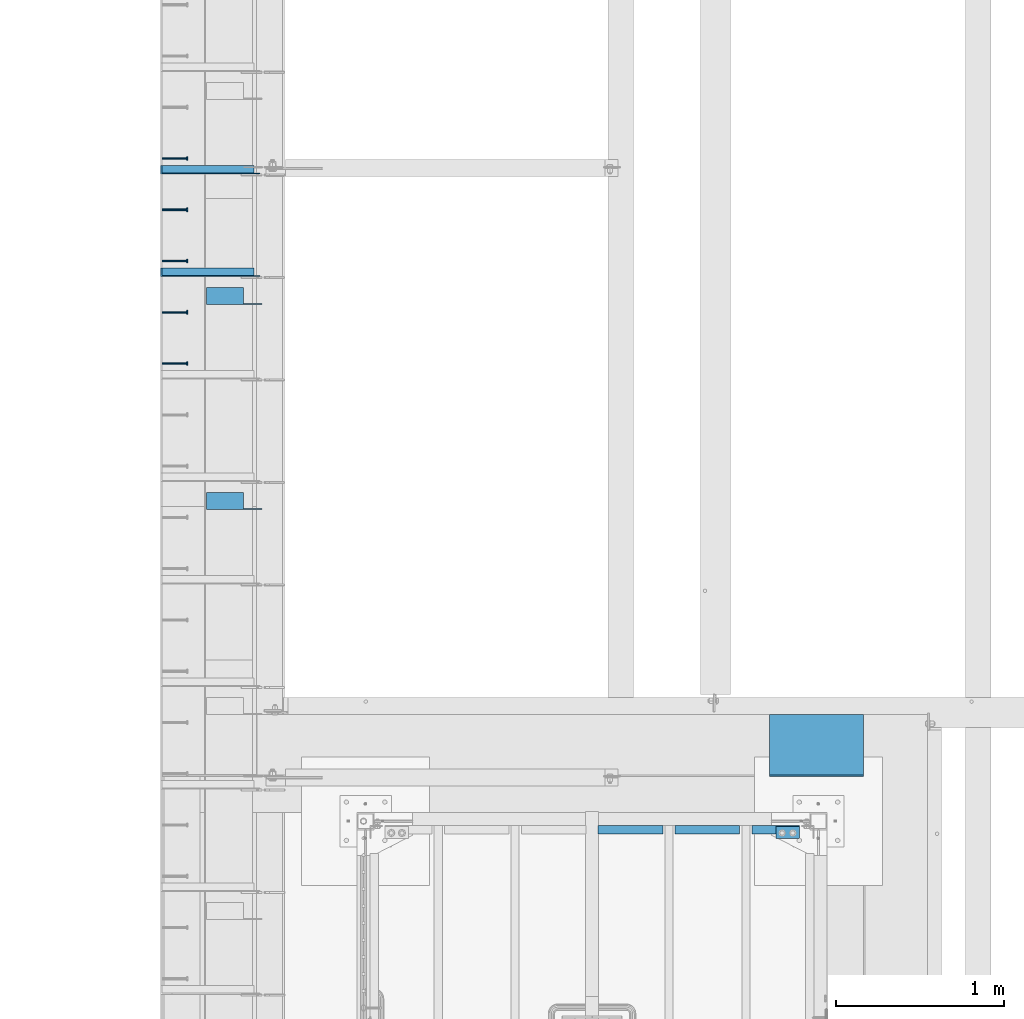
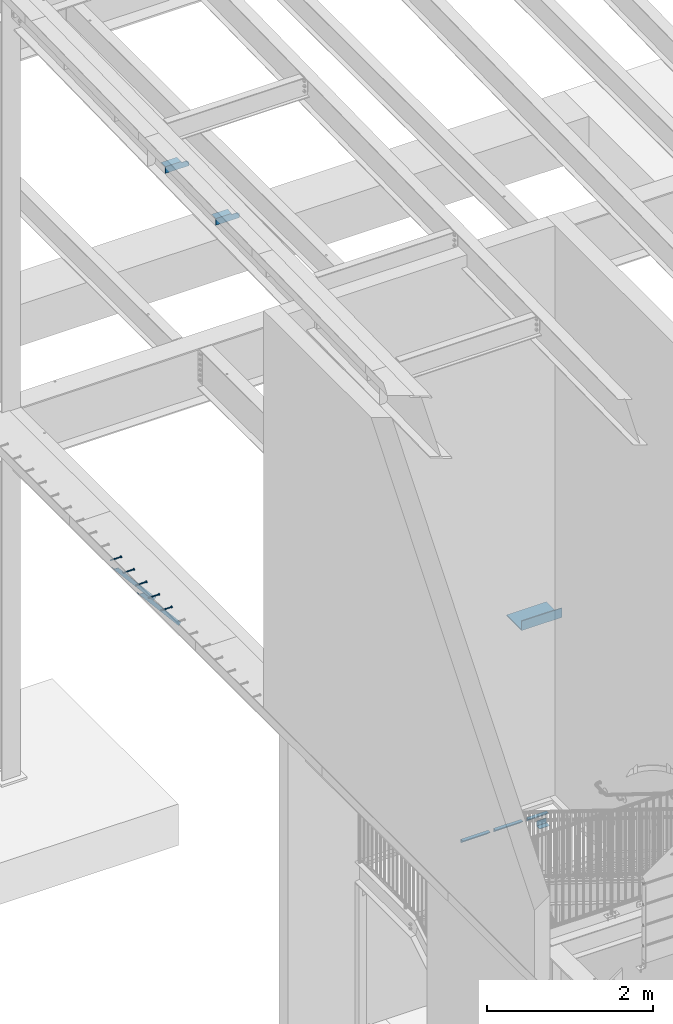
# One storey, part 1278 of 1763: 12 beams, 2 members, 9 elements without a shape of their own.
"""IFC2X3 building model written with IfcOpenShell, lengths in millimetres."""

from ifc_helpers import new_model, si_unit, frame, origin_with_axes, place, context, subcontext, project, spatial, faceted_brep, material, type_object, element, aggregate, save


model = new_model("IFC2X3")

# Units and contexts
model_context = context("Model", 3, precision=1e-05, world=origin_with_axes())
body_context = subcontext(model_context, "Body", "Model", "MODEL_VIEW")
ifc_project = project(units=[si_unit("LENGTHUNIT", "METRE", prefix="MILLI"), si_unit("AREAUNIT", "SQUARE_METRE"), si_unit("VOLUMEUNIT", "CUBIC_METRE"), si_unit("MASSUNIT", "GRAM", prefix="KILO"), si_unit("TIMEUNIT", "SECOND"), si_unit("PLANEANGLEUNIT", "RADIAN"), si_unit("SOLIDANGLEUNIT", "STERADIAN"), si_unit("THERMODYNAMICTEMPERATUREUNIT", "DEGREE_CELSIUS"), si_unit("LUMINOUSINTENSITYUNIT", "LUMEN")], contexts=[model_context])

# Site, building, storey
site_placement = place(None, origin_with_axes())
site = spatial("IfcSite", under=ifc_project, at=site_placement, CompositionType="ELEMENT")
building_placement = place(site_placement, origin_with_axes())
building = spatial("IfcBuilding", under=site, at=building_placement, Name="Undefined", CompositionType="ELEMENT")
storey_placement = place(building_placement, origin_with_axes())
storey = spatial("IfcBuildingStorey", under=building, at=storey_placement, Name="Undefined", CompositionType="ELEMENT", Elevation=0.0)

# Assembly, beam
assembly_1_placement = place(storey_placement, origin_with_axes())
assembly_1 = element("IfcElementAssembly", 1, at=assembly_1_placement, inside=storey, Name="HEADED STUD ANCHOR", AssemblyPlace="NOTDEFINED", PredefinedType="RIGID_FRAME")
ifc_material_1 = material(Name="STEEL/A108")
beam_type_1 = type_object("IfcBeamType", PredefinedType="NOTDEFINED")
beam_1_placement = place(assembly_1_placement, frame((-87975.5122736983, 40020.8750061035, 5268.91250001202), z_axis=(0.0, 0.0, -1.0), x_axis=(1.0, 0.0, 0.0)))
beam_1 = element("IfcBeam", 2, at=beam_1_placement, type_object=beam_type_1, material=ifc_material_1, Name="HEADED STUD ANCHOR", context=body_context, shape_type="Brep", body=[
    faceted_brep([(0.0, -3.1800000667572, 5.5), (0.0, -5.5, 3.1800000667572), (141.732000000002, -5.5, 3.1800000667572), (141.732000000002, -3.1800000667572, 5.5), (0.0, -6.34999999999491, 1.45519152283669e-11), (141.732000000002, -6.34999990463257, 0.0), (0.0, -5.5, -3.1800000667572), (141.732000000002, -5.5, -3.1800000667572), (0.0, -3.1800000667572, -5.5), (141.732000000002, -3.1800000667572, -5.5), (0.0, 0.0, -6.34999990463257), (141.732000000002, 0.0, -6.34999990463257), (0.0, 3.1800000667572, -5.5), (141.732000000002, 3.1800000667572, -5.5), (0.0, 5.5, -3.1800000667572), (141.732000000002, 5.5, -3.1800000667572), (0.0, 6.34999999999491, -2.91038304567337e-11), (141.732000000002, 6.34999990463257, 0.0), (0.0, 5.5, 3.1800000667572), (141.732000000002, 5.5, 3.1800000667572), (0.0, 3.1800000667572, 5.5), (141.732000000002, 3.1800000667572, 5.5), (0.0, 0.0, 6.34999990463257), (141.732000000002, 0.0, 6.34999990463257), (144.780000000001, -10.9899997711182, 6.34999990463257), (144.780000000001, -6.34000015258789, 10.9899997711182), (144.780000000001, -12.6999998092651, 0.0), (144.780000000001, -10.9899997711182, -6.34999990463257), (144.780000000001, -6.34000015258789, -10.9899997711182), (144.780000000001, 0.0, -12.6899995803833), (144.780000000001, 6.34000015258789, -10.9899997711182), (144.780000000001, 10.9899997711182, -6.34999990463257), (144.780000000001, 12.6999998092651, 0.0), (144.780000000001, 10.9899997711182, 6.34999990463257), (144.780000000001, 6.34000015258789, 10.9899997711182), (144.780000000001, 0.0, 12.6899995803833), (152.400000000001, -10.9899997711182, 6.34999990463257), (152.400000000001, -6.34000015258789, 10.9899997711182), (152.400000000001, -12.6999998092651, 0.0), (152.400000000001, -10.9899997711182, -6.34999990463257), (152.400000000001, -6.34000015258789, -10.9899997711182), (152.400000000001, 0.0, -12.6899995803833), (152.400000000001, 6.34000015258789, -10.9899997711182), (152.400000000001, 10.9899997711182, -6.34999990463257), (152.400000000001, 12.6999998092651, 0.0), (152.400000000001, 10.9899997711182, 6.34999990463257), (152.400000000001, 6.34000015258789, 10.9899997711182), (152.400000000001, 0.0, 12.6899995803833)], [[[0, 1, 2, 3]], [[1, 4, 5, 2]], [[4, 6, 7, 5]], [[6, 8, 9, 7]], [[8, 10, 11, 9]], [[10, 12, 13, 11]], [[12, 14, 15, 13]], [[14, 16, 17, 15]], [[16, 18, 19, 17]], [[18, 20, 21, 19]], [[20, 22, 23, 21]], [[22, 0, 3, 23]], [[22, 20, 18, 16, 14, 12, 10, 8, 6, 4, 1, 0]], [[3, 2, 24, 25]], [[2, 5, 26, 24]], [[5, 7, 27, 26]], [[7, 9, 28, 27]], [[9, 11, 29, 28]], [[11, 13, 30, 29]], [[13, 15, 31, 30]], [[15, 17, 32, 31]], [[17, 19, 33, 32]], [[19, 21, 34, 33]], [[21, 23, 35, 34]], [[23, 3, 25, 35]], [[25, 24, 36, 37]], [[24, 26, 38, 36]], [[26, 27, 39, 38]], [[27, 28, 40, 39]], [[28, 29, 41, 40]], [[29, 30, 42, 41]], [[30, 31, 43, 42]], [[31, 32, 44, 43]], [[32, 33, 45, 44]], [[33, 34, 46, 45]], [[34, 35, 47, 46]], [[35, 25, 37, 47]], [[38, 39, 40, 41, 42, 43, 44, 45, 46, 47, 37, 36]]]),
])
aggregate(assembly_1, [beam_1])

assembly_2_placement = place(storey_placement, origin_with_axes())
assembly_2 = element("IfcElementAssembly", 3, at=assembly_2_placement, inside=storey, Name="HEADED STUD ANCHOR", AssemblyPlace="NOTDEFINED", PredefinedType="RIGID_FRAME")
beam_2_placement = place(assembly_2_placement, frame((-87975.5122736983, 40325.6750061035, 5268.91250001202), z_axis=(0.0, 0.0, -1.0), x_axis=(1.0, 0.0, 0.0)))
beam_2 = element("IfcBeam", 4, at=beam_2_placement, type_object=beam_type_1, material=ifc_material_1, Name="HEADED STUD ANCHOR", context=body_context, shape_type="Brep", body=[
    faceted_brep([(0.0, -3.1800000667572, 5.5), (0.0, -5.5, 3.1800000667572), (141.732000000002, -5.5, 3.1800000667572), (141.732000000002, -3.1800000667572, 5.5), (0.0, -6.34999999999491, 1.45519152283669e-11), (141.732000000002, -6.34999990463257, 0.0), (0.0, -5.5, -3.1800000667572), (141.732000000002, -5.5, -3.1800000667572), (0.0, -3.1800000667572, -5.5), (141.732000000002, -3.1800000667572, -5.5), (0.0, 0.0, -6.34999990463257), (141.732000000002, 0.0, -6.34999990463257), (0.0, 3.1800000667572, -5.5), (141.732000000002, 3.1800000667572, -5.5), (0.0, 5.5, -3.1800000667572), (141.732000000002, 5.5, -3.1800000667572), (0.0, 6.34999999999491, -2.91038304567337e-11), (141.732000000002, 6.34999990463257, 0.0), (0.0, 5.5, 3.1800000667572), (141.732000000002, 5.5, 3.1800000667572), (0.0, 3.1800000667572, 5.5), (141.732000000002, 3.1800000667572, 5.5), (0.0, 0.0, 6.34999990463257), (141.732000000002, 0.0, 6.34999990463257), (144.780000000001, -10.9899997711182, 6.34999990463257), (144.780000000001, -6.34000015258789, 10.9899997711182), (144.780000000001, -12.6999998092651, 0.0), (144.780000000001, -10.9899997711182, -6.34999990463257), (144.780000000001, -6.34000015258789, -10.9899997711182), (144.780000000001, 0.0, -12.6899995803833), (144.780000000001, 6.34000015258789, -10.9899997711182), (144.780000000001, 10.9899997711182, -6.34999990463257), (144.780000000001, 12.6999998092651, 0.0), (144.780000000001, 10.9899997711182, 6.34999990463257), (144.780000000001, 6.34000015258789, 10.9899997711182), (144.780000000001, 0.0, 12.6899995803833), (152.400000000001, -10.9899997711182, 6.34999990463257), (152.400000000001, -6.34000015258789, 10.9899997711182), (152.400000000001, -12.6999998092651, 0.0), (152.400000000001, -10.9899997711182, -6.34999990463257), (152.400000000001, -6.34000015258789, -10.9899997711182), (152.400000000001, 0.0, -12.6899995803833), (152.400000000001, 6.34000015258789, -10.9899997711182), (152.400000000001, 10.9899997711182, -6.34999990463257), (152.400000000001, 12.6999998092651, 0.0), (152.400000000001, 10.9899997711182, 6.34999990463257), (152.400000000001, 6.34000015258789, 10.9899997711182), (152.400000000001, 0.0, 12.6899995803833)], [[[0, 1, 2, 3]], [[1, 4, 5, 2]], [[4, 6, 7, 5]], [[6, 8, 9, 7]], [[8, 10, 11, 9]], [[10, 12, 13, 11]], [[12, 14, 15, 13]], [[14, 16, 17, 15]], [[16, 18, 19, 17]], [[18, 20, 21, 19]], [[20, 22, 23, 21]], [[22, 0, 3, 23]], [[22, 20, 18, 16, 14, 12, 10, 8, 6, 4, 1, 0]], [[3, 2, 24, 25]], [[2, 5, 26, 24]], [[5, 7, 27, 26]], [[7, 9, 28, 27]], [[9, 11, 29, 28]], [[11, 13, 30, 29]], [[13, 15, 31, 30]], [[15, 17, 32, 31]], [[17, 19, 33, 32]], [[19, 21, 34, 33]], [[21, 23, 35, 34]], [[23, 3, 25, 35]], [[25, 24, 36, 37]], [[24, 26, 38, 36]], [[26, 27, 39, 38]], [[27, 28, 40, 39]], [[28, 29, 41, 40]], [[29, 30, 42, 41]], [[30, 31, 43, 42]], [[31, 32, 44, 43]], [[32, 33, 45, 44]], [[33, 34, 46, 45]], [[34, 35, 47, 46]], [[35, 25, 37, 47]], [[38, 39, 40, 41, 42, 43, 44, 45, 46, 47, 37, 36]]]),
])
aggregate(assembly_2, [beam_2])

assembly_3_placement = place(storey_placement, origin_with_axes())
assembly_3 = element("IfcElementAssembly", 5, at=assembly_3_placement, inside=storey, Name="HEADED STUD ANCHOR", AssemblyPlace="NOTDEFINED", PredefinedType="RIGID_FRAME")
beam_3_placement = place(assembly_3_placement, frame((-87975.5122736983, 40630.4750061035, 5268.91250001202), z_axis=(0.0, 0.0, -1.0), x_axis=(1.0, 0.0, 0.0)))
beam_3 = element("IfcBeam", 6, at=beam_3_placement, type_object=beam_type_1, material=ifc_material_1, Name="HEADED STUD ANCHOR", context=body_context, shape_type="Brep", body=[
    faceted_brep([(0.0, -3.1800000667572, 5.5), (0.0, -5.5, 3.1800000667572), (141.732000000002, -5.5, 3.1800000667572), (141.732000000002, -3.1800000667572, 5.5), (0.0, -6.34999999999491, 1.45519152283669e-11), (141.732000000002, -6.34999990463257, 0.0), (0.0, -5.5, -3.1800000667572), (141.732000000002, -5.5, -3.1800000667572), (0.0, -3.1800000667572, -5.5), (141.732000000002, -3.1800000667572, -5.5), (0.0, 0.0, -6.34999990463257), (141.732000000002, 0.0, -6.34999990463257), (0.0, 3.1800000667572, -5.5), (141.732000000002, 3.1800000667572, -5.5), (0.0, 5.5, -3.1800000667572), (141.732000000002, 5.5, -3.1800000667572), (0.0, 6.34999999999491, -2.91038304567337e-11), (141.732000000002, 6.34999990463257, 0.0), (0.0, 5.5, 3.1800000667572), (141.732000000002, 5.5, 3.1800000667572), (0.0, 3.1800000667572, 5.5), (141.732000000002, 3.1800000667572, 5.5), (0.0, 0.0, 6.34999990463257), (141.732000000002, 0.0, 6.34999990463257), (144.780000000001, -10.9899997711182, 6.34999990463257), (144.780000000001, -6.34000015258789, 10.9899997711182), (144.780000000001, -12.6999998092651, 0.0), (144.780000000001, -10.9899997711182, -6.34999990463257), (144.780000000001, -6.34000015258789, -10.9899997711182), (144.780000000001, 0.0, -12.6899995803833), (144.780000000001, 6.34000015258789, -10.9899997711182), (144.780000000001, 10.9899997711182, -6.34999990463257), (144.780000000001, 12.6999998092651, 0.0), (144.780000000001, 10.9899997711182, 6.34999990463257), (144.780000000001, 6.34000015258789, 10.9899997711182), (144.780000000001, 0.0, 12.6899995803833), (152.400000000001, -10.9899997711182, 6.34999990463257), (152.400000000001, -6.34000015258789, 10.9899997711182), (152.400000000001, -12.6999998092651, 0.0), (152.400000000001, -10.9899997711182, -6.34999990463257), (152.400000000001, -6.34000015258789, -10.9899997711182), (152.400000000001, 0.0, -12.6899995803833), (152.400000000001, 6.34000015258789, -10.9899997711182), (152.400000000001, 10.9899997711182, -6.34999990463257), (152.400000000001, 12.6999998092651, 0.0), (152.400000000001, 10.9899997711182, 6.34999990463257), (152.400000000001, 6.34000015258789, 10.9899997711182), (152.400000000001, 0.0, 12.6899995803833)], [[[0, 1, 2, 3]], [[1, 4, 5, 2]], [[4, 6, 7, 5]], [[6, 8, 9, 7]], [[8, 10, 11, 9]], [[10, 12, 13, 11]], [[12, 14, 15, 13]], [[14, 16, 17, 15]], [[16, 18, 19, 17]], [[18, 20, 21, 19]], [[20, 22, 23, 21]], [[22, 0, 3, 23]], [[22, 20, 18, 16, 14, 12, 10, 8, 6, 4, 1, 0]], [[3, 2, 24, 25]], [[2, 5, 26, 24]], [[5, 7, 27, 26]], [[7, 9, 28, 27]], [[9, 11, 29, 28]], [[11, 13, 30, 29]], [[13, 15, 31, 30]], [[15, 17, 32, 31]], [[17, 19, 33, 32]], [[19, 21, 34, 33]], [[21, 23, 35, 34]], [[23, 3, 25, 35]], [[25, 24, 36, 37]], [[24, 26, 38, 36]], [[26, 27, 39, 38]], [[27, 28, 40, 39]], [[28, 29, 41, 40]], [[29, 30, 42, 41]], [[30, 31, 43, 42]], [[31, 32, 44, 43]], [[32, 33, 45, 44]], [[33, 34, 46, 45]], [[34, 35, 47, 46]], [[35, 25, 37, 47]], [[38, 39, 40, 41, 42, 43, 44, 45, 46, 47, 37, 36]]]),
])
aggregate(assembly_3, [beam_3])

assembly_4_placement = place(storey_placement, origin_with_axes())
assembly_4 = element("IfcElementAssembly", 7, at=assembly_4_placement, inside=storey, Name="HEADED STUD ANCHOR", AssemblyPlace="NOTDEFINED", PredefinedType="RIGID_FRAME")
beam_4_placement = place(assembly_4_placement, frame((-87975.5122736983, 40935.2750061035, 5268.91250001202), z_axis=(0.0, 0.0, -1.0), x_axis=(1.0, 0.0, 0.0)))
beam_4 = element("IfcBeam", 8, at=beam_4_placement, type_object=beam_type_1, material=ifc_material_1, Name="HEADED STUD ANCHOR", context=body_context, shape_type="Brep", body=[
    faceted_brep([(0.0, -3.1800000667572, 5.5), (0.0, -5.5, 3.1800000667572), (141.732000000002, -5.5, 3.1800000667572), (141.732000000002, -3.1800000667572, 5.5), (0.0, -6.34999999999491, 1.45519152283669e-11), (141.732000000002, -6.34999990463257, 0.0), (0.0, -5.5, -3.1800000667572), (141.732000000002, -5.5, -3.1800000667572), (0.0, -3.1800000667572, -5.5), (141.732000000002, -3.1800000667572, -5.5), (0.0, 0.0, -6.34999990463257), (141.732000000002, 0.0, -6.34999990463257), (0.0, 3.1800000667572, -5.5), (141.732000000002, 3.1800000667572, -5.5), (0.0, 5.5, -3.1800000667572), (141.732000000002, 5.5, -3.1800000667572), (0.0, 6.34999999999491, -2.91038304567337e-11), (141.732000000002, 6.34999990463257, 0.0), (0.0, 5.5, 3.1800000667572), (141.732000000002, 5.5, 3.1800000667572), (0.0, 3.1800000667572, 5.5), (141.732000000002, 3.1800000667572, 5.5), (0.0, 0.0, 6.34999990463257), (141.732000000002, 0.0, 6.34999990463257), (144.780000000001, -10.9899997711182, 6.34999990463257), (144.780000000001, -6.34000015258789, 10.9899997711182), (144.780000000001, -12.6999998092651, 0.0), (144.780000000001, -10.9899997711182, -6.34999990463257), (144.780000000001, -6.34000015258789, -10.9899997711182), (144.780000000001, 0.0, -12.6899995803833), (144.780000000001, 6.34000015258789, -10.9899997711182), (144.780000000001, 10.9899997711182, -6.34999990463257), (144.780000000001, 12.6999998092651, 0.0), (144.780000000001, 10.9899997711182, 6.34999990463257), (144.780000000001, 6.34000015258789, 10.9899997711182), (144.780000000001, 0.0, 12.6899995803833), (152.400000000001, -10.9899997711182, 6.34999990463257), (152.400000000001, -6.34000015258789, 10.9899997711182), (152.400000000001, -12.6999998092651, 0.0), (152.400000000001, -10.9899997711182, -6.34999990463257), (152.400000000001, -6.34000015258789, -10.9899997711182), (152.400000000001, 0.0, -12.6899995803833), (152.400000000001, 6.34000015258789, -10.9899997711182), (152.400000000001, 10.9899997711182, -6.34999990463257), (152.400000000001, 12.6999998092651, 0.0), (152.400000000001, 10.9899997711182, 6.34999990463257), (152.400000000001, 6.34000015258789, 10.9899997711182), (152.400000000001, 0.0, 12.6899995803833)], [[[0, 1, 2, 3]], [[1, 4, 5, 2]], [[4, 6, 7, 5]], [[6, 8, 9, 7]], [[8, 10, 11, 9]], [[10, 12, 13, 11]], [[12, 14, 15, 13]], [[14, 16, 17, 15]], [[16, 18, 19, 17]], [[18, 20, 21, 19]], [[20, 22, 23, 21]], [[22, 0, 3, 23]], [[22, 20, 18, 16, 14, 12, 10, 8, 6, 4, 1, 0]], [[3, 2, 24, 25]], [[2, 5, 26, 24]], [[5, 7, 27, 26]], [[7, 9, 28, 27]], [[9, 11, 29, 28]], [[11, 13, 30, 29]], [[13, 15, 31, 30]], [[15, 17, 32, 31]], [[17, 19, 33, 32]], [[19, 21, 34, 33]], [[21, 23, 35, 34]], [[23, 3, 25, 35]], [[25, 24, 36, 37]], [[24, 26, 38, 36]], [[26, 27, 39, 38]], [[27, 28, 40, 39]], [[28, 29, 41, 40]], [[29, 30, 42, 41]], [[30, 31, 43, 42]], [[31, 32, 44, 43]], [[32, 33, 45, 44]], [[33, 34, 46, 45]], [[34, 35, 47, 46]], [[35, 25, 37, 47]], [[38, 39, 40, 41, 42, 43, 44, 45, 46, 47, 37, 36]]]),
])
aggregate(assembly_4, [beam_4])

assembly_5_placement = place(storey_placement, origin_with_axes())
assembly_5 = element("IfcElementAssembly", 9, at=assembly_5_placement, inside=storey, Name="HEADED STUD ANCHOR", AssemblyPlace="NOTDEFINED", PredefinedType="RIGID_FRAME")
beam_5_placement = place(assembly_5_placement, frame((-87975.5122736983, 41240.0750061035, 5268.91250001202), z_axis=(0.0, 0.0, -1.0), x_axis=(1.0, 0.0, 0.0)))
beam_5 = element("IfcBeam", 10, at=beam_5_placement, type_object=beam_type_1, material=ifc_material_1, Name="HEADED STUD ANCHOR", context=body_context, shape_type="Brep", body=[
    faceted_brep([(0.0, -3.1800000667572, 5.5), (0.0, -5.5, 3.1800000667572), (141.732000000002, -5.5, 3.1800000667572), (141.732000000002, -3.1800000667572, 5.5), (0.0, -6.34999999999491, 1.45519152283669e-11), (141.732000000002, -6.34999990463257, 0.0), (0.0, -5.5, -3.1800000667572), (141.732000000002, -5.5, -3.1800000667572), (0.0, -3.1800000667572, -5.5), (141.732000000002, -3.1800000667572, -5.5), (0.0, 0.0, -6.34999990463257), (141.732000000002, 0.0, -6.34999990463257), (0.0, 3.1800000667572, -5.5), (141.732000000002, 3.1800000667572, -5.5), (0.0, 5.5, -3.1800000667572), (141.732000000002, 5.5, -3.1800000667572), (0.0, 6.34999999999491, -2.91038304567337e-11), (141.732000000002, 6.34999990463257, 0.0), (0.0, 5.5, 3.1800000667572), (141.732000000002, 5.5, 3.1800000667572), (0.0, 3.1800000667572, 5.5), (141.732000000002, 3.1800000667572, 5.5), (0.0, 0.0, 6.34999990463257), (141.732000000002, 0.0, 6.34999990463257), (144.780000000001, -10.9899997711182, 6.34999990463257), (144.780000000001, -6.34000015258789, 10.9899997711182), (144.780000000001, -12.6999998092651, 0.0), (144.780000000001, -10.9899997711182, -6.34999990463257), (144.780000000001, -6.34000015258789, -10.9899997711182), (144.780000000001, 0.0, -12.6899995803833), (144.780000000001, 6.34000015258789, -10.9899997711182), (144.780000000001, 10.9899997711182, -6.34999990463257), (144.780000000001, 12.6999998092651, 0.0), (144.780000000001, 10.9899997711182, 6.34999990463257), (144.780000000001, 6.34000015258789, 10.9899997711182), (144.780000000001, 0.0, 12.6899995803833), (152.400000000001, -10.9899997711182, 6.34999990463257), (152.400000000001, -6.34000015258789, 10.9899997711182), (152.400000000001, -12.6999998092651, 0.0), (152.400000000001, -10.9899997711182, -6.34999990463257), (152.400000000001, -6.34000015258789, -10.9899997711182), (152.400000000001, 0.0, -12.6899995803833), (152.400000000001, 6.34000015258789, -10.9899997711182), (152.400000000001, 10.9899997711182, -6.34999990463257), (152.400000000001, 12.6999998092651, 0.0), (152.400000000001, 10.9899997711182, 6.34999990463257), (152.400000000001, 6.34000015258789, 10.9899997711182), (152.400000000001, 0.0, 12.6899995803833)], [[[0, 1, 2, 3]], [[1, 4, 5, 2]], [[4, 6, 7, 5]], [[6, 8, 9, 7]], [[8, 10, 11, 9]], [[10, 12, 13, 11]], [[12, 14, 15, 13]], [[14, 16, 17, 15]], [[16, 18, 19, 17]], [[18, 20, 21, 19]], [[20, 22, 23, 21]], [[22, 0, 3, 23]], [[22, 20, 18, 16, 14, 12, 10, 8, 6, 4, 1, 0]], [[3, 2, 24, 25]], [[2, 5, 26, 24]], [[5, 7, 27, 26]], [[7, 9, 28, 27]], [[9, 11, 29, 28]], [[11, 13, 30, 29]], [[13, 15, 31, 30]], [[15, 17, 32, 31]], [[17, 19, 33, 32]], [[19, 21, 34, 33]], [[21, 23, 35, 34]], [[23, 3, 25, 35]], [[25, 24, 36, 37]], [[24, 26, 38, 36]], [[26, 27, 39, 38]], [[27, 28, 40, 39]], [[28, 29, 41, 40]], [[29, 30, 42, 41]], [[30, 31, 43, 42]], [[31, 32, 44, 43]], [[32, 33, 45, 44]], [[33, 34, 46, 45]], [[34, 35, 47, 46]], [[35, 25, 37, 47]], [[38, 39, 40, 41, 42, 43, 44, 45, 46, 47, 37, 36]]]),
])
aggregate(assembly_5, [beam_5])

# Assembly, members
assembly_6_placement = place(storey_placement, origin_with_axes())
assembly_6 = element("IfcElementAssembly", 11, at=assembly_6_placement, inside=storey, Name="BEAM", AssemblyPlace="NOTDEFINED", PredefinedType="RIGID_FRAME")
ifc_material_2 = material(Name="STEEL/A36")
member_type = type_object("IfcMemberType", Name="L2X2X1/4", PredefinedType="NOTDEFINED")
member_1_placement = place(assembly_6_placement, frame((-87414.1929584935, 41173.4, 4557.35349338836), z_axis=(0.764183480307171, 0.0, 0.644998921259268), x_axis=(-0.644998921259266, 0.0, 0.764183480307173)))
member_1 = element("IfcMember", 12, at=member_1_placement, type_object=member_type, material=ifc_material_2, Name="ANGLE", ObjectType="L2X2X1/4", context=body_context, shape_type="Brep", body=[
    faceted_brep([(-1.45519152283669e-11, 25.4000000000015, -25.3999999999869), (1.45519152283669e-11, 25.4000000000015, 25.3999999999796), (812.060911532491, 25.4000000000015, 25.400000001966), (854.937976763787, 25.4000000000015, -25.3999999979424), (1.45519152283669e-11, 19.0499999999993, 25.3999999999796), (812.060911532491, 19.0500000000029, 25.400000001966), (-7.27595761418343e-12, 19.0499999999993, -19.0499999999956), (849.578343609872, 19.0500000000029, -19.0499999979511), (-7.27595761418343e-12, -25.4000000000015, -19.0499999999956), (849.578343609872, -25.4000000000015, -19.0499999979511), (-1.45519152283669e-11, -25.4000000000015, -25.3999999999869), (854.937976763787, -25.4000000000015, -25.3999999979424)], [[[0, 1, 2, 3]], [[1, 4, 5, 2]], [[4, 6, 7, 5]], [[6, 8, 9, 7]], [[8, 10, 11, 9]], [[10, 0, 3, 11]], [[5, 7, 9, 11, 3, 2]], [[10, 8, 6, 4, 1, 0]]]),
])
member_2_placement = place(assembly_6_placement, frame((-87414.1929584935, 40563.8, 4557.35349338836), z_axis=(0.764183480307171, 0.0, 0.644998921259268), x_axis=(-0.644998921259266, 0.0, 0.764183480307173)))
member_2 = element("IfcMember", 13, at=member_2_placement, type_object=member_type, material=ifc_material_2, Name="ANGLE", ObjectType="L2X2X1/4", context=body_context, shape_type="Brep", body=[
    faceted_brep([(-1.45519152283669e-11, 25.4000000000015, -25.3999999999869), (1.45519152283669e-11, 25.4000000000015, 25.3999999999796), (812.060911532491, 25.4000000000015, 25.400000001966), (854.937976763787, 25.4000000000015, -25.3999999979424), (1.45519152283669e-11, 19.0499999999993, 25.3999999999796), (812.060911532491, 19.0500000000029, 25.400000001966), (-7.27595761418343e-12, 19.0499999999993, -19.0499999999956), (849.578343609872, 19.0500000000029, -19.0499999979511), (-7.27595761418343e-12, -25.4000000000015, -19.0499999999956), (849.578343609872, -25.4000000000015, -19.0499999979511), (-1.45519152283669e-11, -25.4000000000015, -25.3999999999869), (854.937976763787, -25.4000000000015, -25.3999999979424)], [[[0, 1, 2, 3]], [[1, 4, 5, 2]], [[4, 6, 7, 5]], [[6, 8, 9, 7]], [[8, 10, 11, 9]], [[10, 0, 3, 11]], [[5, 7, 9, 11, 3, 2]], [[10, 8, 6, 4, 1, 0]]]),
])
aggregate(assembly_6, [member_1, member_2])

# Assembly, beams
assembly_7_placement = place(storey_placement, origin_with_axes())
assembly_7 = element("IfcElementAssembly", 14, at=assembly_7_placement, inside=storey, Name="BEAM", AssemblyPlace="NOTDEFINED", PredefinedType="RIGID_FRAME")
beam_type_2 = type_object("IfcBeamType", Name="L4X4X1/4", PredefinedType="NOTDEFINED")
beam_6_placement = place(assembly_7_placement, frame((-87711.9872706466, 40422.9502677201, 11454.6646472917), z_axis=(0.0, 0.0206852279954837, -0.999786037781472), x_axis=(1.0, 0.0, 0.0)))
beam_6 = element("IfcBeam", 15, at=beam_6_placement, type_object=beam_type_2, material=ifc_material_2, Name="BRACE", ObjectType="L4X4X1/4", context=body_context, shape_type="Brep", body=[
    faceted_brep([(220.662761923406, 44.4500000001208, -44.4499999999807), (220.662761962012, -50.800000000163, -44.4499999999553), (220.66276795695, -50.800000000163, -50.7999999999502), (220.662767915564, 50.8000000001339, -50.7999999999774), (220.662751535681, 50.8000000001339, -33.3786578752915), (220.662751538272, 44.4500000001208, -33.3786578752897), (299.243730570859, 44.4500000001135, -33.3375021376705), (299.243730570859, 50.8000000001339, -33.3375021376723), (2.11002770811319e-10, -50.8000000000357, -50.799999999952), (1.96450855582952e-10, -50.8000000000338, -44.4499999999534), (-2.18278728425503e-11, 44.4500000000007, -44.450000000048), (-1.81898940354586e-10, 44.4500000000371, 50.7999999999374), (-1.96450855582952e-10, 50.8000000000393, 50.7999999999374), (-3.63797880709171e-11, 50.8000000000011, -50.8000000000538), (330.993731689443, 44.4500000000007, 50.7999999999993), (330.993731689443, 50.7999999999993, 50.7999999999993), (330.993730570859, 44.4500000001281, -1.58750213774329), (330.993746948254, 50.8000000001412, -1.5875021377451)], [[[0, 1, 2, 3, 4, 5]], [[6, 5, 4, 7]], [[8, 9, 10, 11, 12, 13]], [[12, 11, 14, 15]], [[15, 14, 16, 17]], [[17, 16, 6, 7]], [[3, 13, 12, 15, 17, 7, 4]], [[8, 13, 3, 2]], [[9, 8, 2, 1]], [[10, 9, 1, 0]], [[16, 14, 11, 10, 0, 5, 6]]]),
])
beam_7_placement = place(assembly_7_placement, frame((-87711.9872706466, 39204.0111304571, 11429.4452173197), z_axis=(0.0, 0.0206852279954837, -0.999786037781472), x_axis=(1.0, 0.0, 0.0)))
beam_7 = element("IfcBeam", 16, at=beam_7_placement, type_object=beam_type_2, material=ifc_material_2, Name="BRACE", ObjectType="L4X4X1/4", context=body_context, shape_type="Brep", body=[
    faceted_brep([(220.662761923406, 44.4500000001208, -44.4499999999807), (220.662761962012, -50.800000000163, -44.4499999999553), (220.66276795695, -50.800000000163, -50.7999999999502), (220.662767915564, 50.8000000001339, -50.7999999999774), (220.662751535681, 50.8000000001339, -33.3786578752915), (220.662751538272, 44.4500000001208, -33.3786578752897), (299.243730570859, 44.4500000001135, -33.3375021376705), (299.243730570859, 50.8000000001339, -33.3375021376723), (2.11002770811319e-10, -50.8000000000357, -50.799999999952), (1.96450855582952e-10, -50.8000000000338, -44.4499999999534), (-2.18278728425503e-11, 44.4500000000007, -44.450000000048), (-1.81898940354586e-10, 44.4500000000371, 50.7999999999374), (-1.96450855582952e-10, 50.8000000000393, 50.7999999999374), (-3.63797880709171e-11, 50.8000000000011, -50.8000000000538), (330.993731689443, 44.4500000000007, 50.7999999999993), (330.993731689443, 50.7999999999993, 50.7999999999993), (330.993730570859, 44.4500000001281, -1.58750213774329), (330.993746948254, 50.8000000001412, -1.5875021377451)], [[[0, 1, 2, 3, 4, 5]], [[6, 5, 4, 7]], [[8, 9, 10, 11, 12, 13]], [[12, 11, 14, 15]], [[15, 14, 16, 17]], [[17, 16, 6, 7]], [[3, 13, 12, 15, 17, 7, 4]], [[8, 13, 3, 2]], [[9, 8, 2, 1]], [[10, 9, 1, 0]], [[16, 14, 11, 10, 0, 5, 6]]]),
])
aggregate(assembly_7, [beam_6, beam_7])

assembly_8_placement = place(storey_placement, origin_with_axes())
assembly_8 = element("IfcElementAssembly", 17, at=assembly_8_placement, inside=storey, Name="STRINGER", AssemblyPlace="NOTDEFINED", PredefinedType="RIGID_FRAME")
beam_type_3 = type_object("IfcBeamType", Name="L2X2X1/4", PredefinedType="NOTDEFINED")
beam_8_placement = place(assembly_8_placement, frame((-84541.6831878093, 37249.1000000016, 2630.48749999996), z_axis=(0.0, 0.0, -1.0), x_axis=(-1.0, 0.0, 0.0)))
beam_8 = element("IfcBeam", 18, at=beam_8_placement, type_object=beam_type_3, material=ifc_material_2, Name="ANGLE", ObjectType="L2X2X1/4", context=body_context, shape_type="Brep", body=[
    faceted_brep([(-1.45519152283669e-11, 25.4000000000015, -25.3999999999869), (1.45519152283669e-11, 25.4000000000015, 25.3999999999796), (384.307732435307, 25.4000000000015, 25.4000000000001), (384.307732435307, 25.4000000000015, -25.4000000000001), (1.45519152283669e-11, 19.0499999999993, 25.3999999999796), (384.307732435307, 19.0500000000029, 25.4000000000001), (-7.27595761418343e-12, 19.0499999999993, -19.0499999999956), (384.307732435307, 19.0500000000029, -19.0500000000002), (-7.27595761418343e-12, -25.4000000000015, -19.0499999999956), (384.307732435307, -25.4000000000015, -19.0500000000002), (-1.45519152283669e-11, -25.4000000000015, -25.3999999999869), (384.307732435307, -25.4000000000015, -25.4000000000001)], [[[0, 1, 2, 3]], [[1, 4, 5, 2]], [[4, 6, 7, 5]], [[6, 8, 9, 7]], [[8, 10, 11, 9]], [[10, 0, 3, 11]], [[5, 7, 9, 11, 3, 2]], [[10, 8, 6, 4, 1, 0]]]),
])
beam_9_placement = place(assembly_8_placement, frame((-84999.0158128093, 37249.1000000016, 2630.48749999996), z_axis=(0.0, 0.0, -1.0), x_axis=(-1.0, 0.0, 0.0)))
beam_9 = element("IfcBeam", 19, at=beam_9_placement, type_object=beam_type_3, material=ifc_material_2, Name="ANGLE", ObjectType="L2X2X1/4", context=body_context, shape_type="Brep", body=[
    faceted_brep([(-1.45519152283669e-11, 25.4000000000015, -25.3999999999869), (1.45519152283669e-11, 25.4000000000015, 25.3999999999796), (384.10862775179, 25.4000000000015, 25.4000000000001), (384.10862775179, 25.4000000000015, -25.4000000000001), (1.45519152283669e-11, 19.0499999999993, 25.3999999999796), (384.10862775179, 19.0500000000029, 25.4000000000001), (-7.27595761418343e-12, 19.0499999999993, -19.0499999999956), (384.10862775179, 19.0500000000029, -19.0500000000002), (-7.27595761418343e-12, -25.4000000000015, -19.0499999999956), (384.10862775179, -25.4000000000015, -19.0500000000002), (-1.45519152283669e-11, -25.4000000000015, -25.3999999999869), (384.10862775179, -25.4000000000015, -25.4000000000001)], [[[0, 1, 2, 3]], [[1, 4, 5, 2]], [[4, 6, 7, 5]], [[6, 8, 9, 7]], [[8, 10, 11, 9]], [[10, 0, 3, 11]], [[5, 7, 9, 11, 3, 2]], [[10, 8, 6, 4, 1, 0]]]),
])
beam_10_placement = place(assembly_8_placement, frame((-84187.6721007389, 37249.1000000016, 2630.48749999998), z_axis=(0.0, 0.0, -1.0), x_axis=(-1.0, 0.0, 0.0)))
beam_10 = element("IfcBeam", 20, at=beam_10_placement, type_object=beam_type_3, material=ifc_material_2, Name="ANGLE", ObjectType="L2X2X1/4", context=body_context, shape_type="Brep", body=[
    faceted_brep([(-1.45519152283669e-11, 25.4000000000015, -25.3999999999869), (1.45519152283669e-11, 25.4000000000015, 25.3999999999796), (280.986527847475, 25.4000000000015, 25.4000000000001), (280.986527847475, 25.4000000000015, -25.4000000000001), (1.45519152283669e-11, 19.0499999999993, 25.3999999999796), (280.986527847475, 19.0500000000029, 25.4000000000001), (-7.27595761418343e-12, 19.0499999999993, -19.0499999999956), (280.986527847475, 19.0500000000029, -19.0500000000002), (-7.27595761418343e-12, -25.4000000000015, -19.0499999999956), (280.986527847475, -25.4000000000015, -19.0500000000002), (-1.45519152283669e-11, -25.4000000000015, -25.3999999999869), (280.986527847475, -25.4000000000015, -25.4000000000001)], [[[0, 1, 2, 3]], [[1, 4, 5, 2]], [[4, 6, 7, 5]], [[6, 8, 9, 7]], [[8, 10, 11, 9]], [[10, 0, 3, 11]], [[5, 7, 9, 11, 3, 2]], [[10, 8, 6, 4, 1, 0]]]),
])
beam_type_4 = type_object("IfcBeamType", Name="L3X3X1/4", PredefinedType="NOTDEFINED")
beam_11_placement = place(assembly_8_placement, frame((-84187.7372737337, 37236.4000000016, 2516.18750001402), z_axis=(0.0, -1.0, 0.0), x_axis=(-1.0, 0.0, 0.0)))
beam_11 = element("IfcBeam", 21, at=beam_11_placement, type_object=beam_type_4, material=ifc_material_2, Name="ANGLE", ObjectType="L3X3X1/4", context=body_context, shape_type="Brep", body=[
    faceted_brep([(0.0, 38.0999999999985, -38.1000000000004), (0.0, 38.0999999999985, 38.1000000000004), (139.699999999999, 38.1000000000058, 38.0999999999985), (139.699999999999, 38.1000000000058, -38.0999999999985), (0.0, 31.75, 38.1000000000058), (139.699999999999, 31.75, 38.0999999999985), (0.0, 31.75, -31.75), (139.699999999999, 31.75, -31.75), (0.0, -38.1000000000004, -31.75), (139.699999999999, -38.1000000000058, -31.75), (0.0, -38.0999999999985, -38.1000000000004), (139.699999999999, -38.1000000000058, -38.0999999999985)], [[[0, 1, 2, 3]], [[1, 4, 5, 2]], [[4, 6, 7, 5]], [[6, 8, 9, 7]], [[8, 10, 11, 9]], [[10, 0, 3, 11]], [[5, 7, 9, 11, 3, 2]], [[10, 8, 6, 4, 1, 0]]]),
])
aggregate(assembly_8, [beam_11, beam_8, beam_9, beam_10])

# Assembly, beam
assembly_9_placement = place(storey_placement, origin_with_axes())
assembly_9 = element("IfcElementAssembly", 22, at=assembly_9_placement, inside=storey, Name="BEAM", AssemblyPlace="NOTDEFINED", PredefinedType="RIGID_FRAME")
beam_type_5 = type_object("IfcBeamType", PredefinedType="NOTDEFINED")
beam_12_placement = place(assembly_9_placement, frame((-84085.4760236983, 37934.9, 5199.0625), z_axis=(-1.0, 0.0, 0.0), x_axis=(0.0, -1.0, 0.0)))
beam_12 = element("IfcBeam", 23, at=beam_12_placement, type_object=beam_type_5, material=ifc_material_2, Name="BENT_PLATE", context=body_context, shape_type="Brep", body=[
    faceted_brep([(0.0, -4.76249999999982, -279.267500000002), (0.0, -4.76249999999982, 279.267500000002), (0.0, 4.76249999999982, 279.267500000002), (0.0, 4.76249999999982, -279.267500000002), (358.774987792975, 4.76249999999982, 279.267500000002), (358.774987792975, 4.76249999999982, -279.267500000002), (368.299987792969, -4.76249999999982, -279.267500000002), (368.299987792969, -4.76249999999982, 279.267500000002), (358.774987792975, 134.937496948242, 279.267500000002), (358.774987792975, 134.937496948242, -279.267500000002), (368.299987792969, 134.937496948242, 279.267500000002), (368.299987792969, 134.937496948242, -279.267500000002)], [[[0, 1, 2, 3]], [[3, 2, 4, 5]], [[1, 0, 6, 7]], [[5, 4, 8, 9]], [[4, 2, 1, 7, 10, 8]], [[7, 6, 11, 10]], [[6, 0, 3, 5, 9, 11]], [[10, 11, 9, 8]]]),
])
aggregate(assembly_9, [beam_12])

save(model, "model.ifc")
